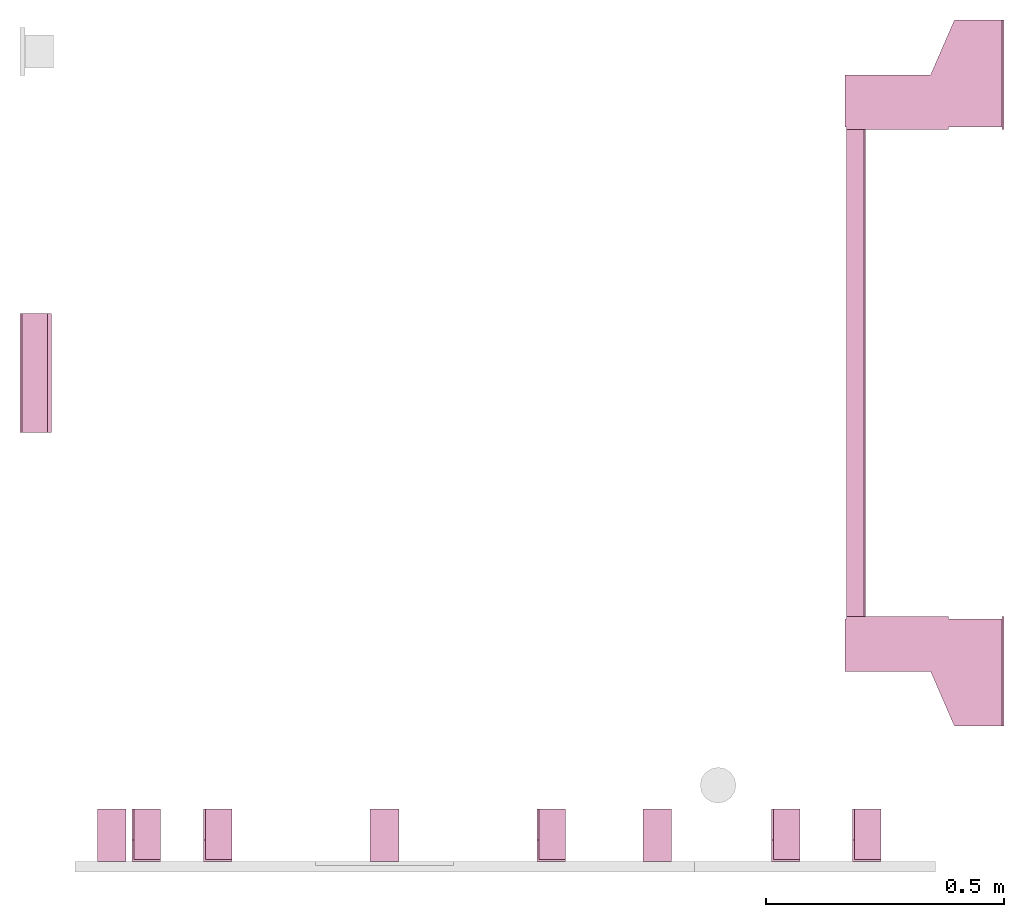
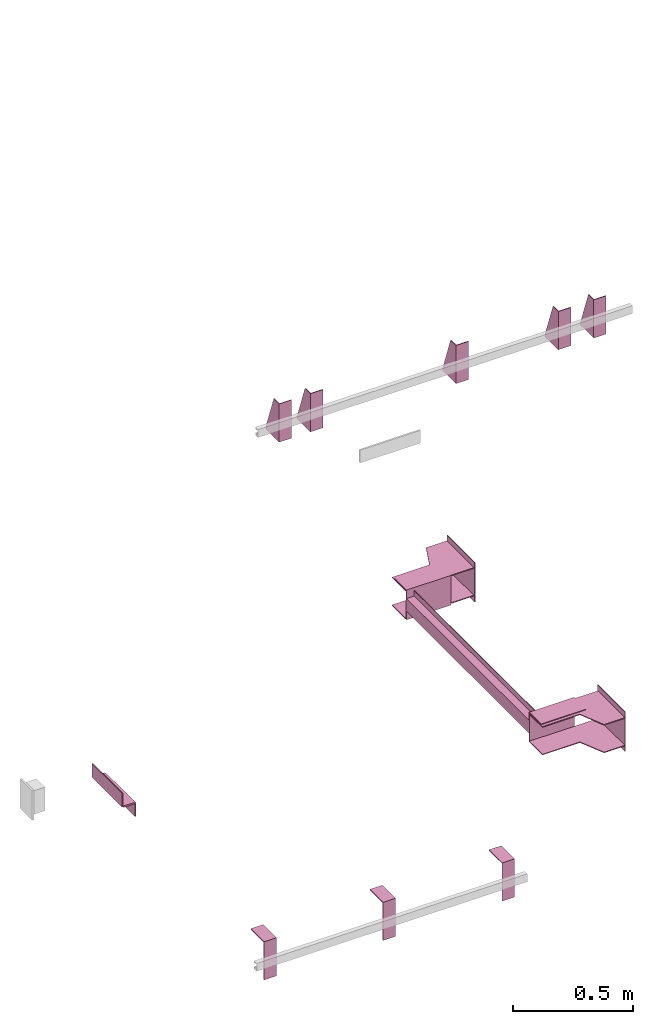
# One storey, part 4 of 4: 10 transport elements.
"""IFC4 building model written with IfcOpenShell, lengths in millimetres."""

from ifc_helpers import new_model, entity, si_unit, converted_unit, frame, origin_with_axes, place, context, subcontext, project, spatial, faceted_brep, element, save


model = new_model("IFC4")

# Units and contexts
context_of_model = context(None, 3, precision=0.01, world=origin_with_axes())
sub_context_1 = subcontext(context_of_model, None, None, "MODEL_VIEW")
sub_context_2 = subcontext(context_of_model, None, None, "MODEL_VIEW")
sub_context_3 = subcontext(context_of_model, None, None, "MODEL_VIEW")
sub_context_4 = subcontext(context_of_model, None, None, "MODEL_VIEW")
sub_context_5 = subcontext(context_of_model, None, None, "MODEL_VIEW")
sub_context_6 = subcontext(context_of_model, None, None, "MODEL_VIEW")
sub_context_7 = subcontext(context_of_model, None, None, "MODEL_VIEW")
sub_context_8 = subcontext(context_of_model, None, None, "MODEL_VIEW")
sub_context_9 = subcontext(context_of_model, None, None, "MODEL_VIEW")
sub_context_10 = subcontext(context_of_model, None, None, "MODEL_VIEW")
ifc_project = project(units=[converted_unit("PLANEANGLEUNIT", "degree", entity("IfcPlaneAngleMeasure", 0.017453292519943), si_unit("PLANEANGLEUNIT", "RADIAN"), dimensions=[0, 0, 0, 0, 0, 0, 0]), si_unit("LENGTHUNIT", "METRE", prefix="MILLI"), si_unit("MASSUNIT", "GRAM", prefix="KILO"), converted_unit("TIMEUNIT", "year", entity("IfcTimeMeasure", 31557600.0), si_unit("TIMEUNIT", "SECOND"), dimensions=[0, 0, 1, 0, 0, 0, 0]), si_unit("THERMODYNAMICTEMPERATUREUNIT", "DEGREE_CELSIUS"), si_unit("AREAUNIT", "SQUARE_METRE"), si_unit("FORCEUNIT", "NEWTON"), si_unit("VOLUMEUNIT", "CUBIC_METRE"), si_unit("PRESSUREUNIT", "PASCAL"), si_unit("SOLIDANGLEUNIT", "STERADIAN")], contexts=[context_of_model])

# Site, building, storey
site = spatial("IfcSite", under=ifc_project)
building = spatial("IfcBuilding", under=site, Name="Document")
placement = place(None, origin_with_axes())
storey_placement = place(placement, frame((0.0, 0.0, -20400.0), z_axis=(0.0, 0.0, 1.0), x_axis=(1.0, 0.0, 0.0)))
storey = spatial("IfcBuildingStorey", under=building, at=storey_placement, Name="P8", Elevation=-20400.0)

# Transport elements
transport_element_1_placement = place(storey_placement, frame((2065.0, 1025.0, 200.0), z_axis=(0.0, 0.0, 1.0), x_axis=(0.0, 1.0, 0.0)))
element("IfcTransportElement", 1, at=transport_element_1_placement, inside=storey, PredefinedType="ELEVATOR", context=sub_context_1, shape_type="Brep", body=[
    faceted_brep([(-611.0, 331.0, -72.5), (-514.0, 331.0, -72.5), (-514.0, 331.0, 72.5), (-611.0, 331.0, 72.5), (-611.0, 331.0, 75.5), (-511.0, 331.0, 75.5), (-511.0, 331.0, -75.5), (-611.0, 331.0, -75.5), (-511.0, 116.0, -75.5), (-511.0, 116.0, 75.5), (-611.0, 116.0, 75.5), (-611.0, 116.0, 72.5), (-514.0, 116.0, 72.5), (-514.0, 116.0, -72.5), (-611.0, 116.0, -72.5), (-611.0, 116.0, -75.5)], [[[0, 1, 2, 3, 4, 5, 6, 7]], [[8, 9, 10, 11, 12, 13, 14, 15]], [[15, 14, 0, 7]], [[13, 12, 2, 1]], [[5, 9, 8, 6]], [[11, 10, 4, 3]], [[6, 8, 15, 7]], [[14, 13, 1, 0]], [[2, 12, 11, 3]], [[10, 9, 5, 4]]]),
    faceted_brep([(-511.0, 291.0, 59.5), (-511.0, 294.0, 59.5), (-511.0, 294.0, 32.5), (-511.0, 291.0, 32.5), (511.0, 291.0, 59.5), (511.0, 291.0, 32.5), (511.0, 294.0, 32.5), (511.0, 294.0, 59.5)], [[[0, 1, 2, 3]], [[4, 5, 6, 7]], [[0, 3, 5, 4]], [[3, 2, 6, 5]], [[2, 1, 7, 6]], [[1, 0, 4, 7]]]),
    faceted_brep([(511.0, 331.0, 75.5), (611.0, 331.0, 75.5), (611.0, 331.0, 72.5), (514.0, 331.0, 72.5), (514.0, 331.0, -72.5), (611.0, 331.0, -72.5), (611.0, 331.0, -75.5), (511.0, 331.0, -75.5), (511.0, 116.0, -75.5), (611.0, 116.0, -75.5), (611.0, 116.0, -72.5), (514.0, 116.0, -72.5), (514.0, 116.0, 72.5), (611.0, 116.0, 72.5), (611.0, 116.0, 75.5), (511.0, 116.0, 75.5)], [[[0, 1, 2, 3, 4, 5, 6, 7]], [[8, 9, 10, 11, 12, 13, 14, 15]], [[8, 15, 0, 7]], [[3, 12, 11, 4]], [[5, 10, 9, 6]], [[1, 14, 13, 2]], [[6, 9, 8, 7]], [[11, 10, 5, 4]], [[15, 14, 1, 0]], [[2, 13, 12, 3]]]),
    faceted_brep([(-511.0, 291.0, -32.5), (-511.0, 294.0, -32.5), (-511.0, 294.0, -59.5), (-511.0, 291.0, -59.5), (511.0, 291.0, -32.5), (511.0, 291.0, -59.5), (511.0, 294.0, -59.5), (511.0, 294.0, -32.5)], [[[0, 1, 2, 3]], [[4, 5, 6, 7]], [[0, 3, 5, 4]], [[3, 2, 6, 5]], [[2, 1, 7, 6]], [[1, 0, 4, 7]]]),
    faceted_brep([(-511.0, 331.0, 32.5), (511.0, 331.0, 32.5), (511.0, 331.0, -32.5), (-511.0, 331.0, -32.5), (511.0, 328.0, -29.5), (511.0, 328.0, 29.5), (-511.0, 328.0, 29.5), (-511.0, 328.0, -29.5), (511.0, 291.0, -32.5), (511.0, 291.0, -29.5), (-511.0, 291.0, -29.5), (-511.0, 291.0, -32.5), (511.0, 291.0, 29.5), (511.0, 291.0, 32.5), (-511.0, 291.0, 32.5), (-511.0, 291.0, 29.5)], [[[0, 1, 2, 3]], [[4, 5, 6, 7]], [[8, 9, 10, 11]], [[12, 13, 14, 15]], [[11, 10, 7, 6, 15, 14, 0, 3]], [[2, 1, 13, 12, 5, 4, 9, 8]], [[2, 8, 11, 3]], [[10, 9, 4, 7]], [[14, 13, 1, 0]], [[5, 12, 15, 6]]]),
    faceted_brep([(-626.0, 334.0, 72.5), (-516.0, 334.0, 72.5), (-516.0, 334.0, 68.5), (-626.0, 334.0, 68.5), (-516.0, 4.0, 68.5), (-516.0, 4.0, 72.5), (-741.0, 4.0, 72.5), (-741.0, 4.0, 68.5), (-741.0, 104.0, 72.5), (-626.0, 154.0, 72.5), (-626.0, 154.0, 68.5), (-741.0, 104.0, 68.5)], [[[0, 1, 2, 3]], [[4, 5, 6, 7]], [[8, 9, 10, 11]], [[10, 9, 0, 3]], [[1, 5, 4, 2]], [[7, 6, 8, 11]], [[2, 4, 7, 11, 10, 3]], [[9, 8, 6, 5, 1, 0]]]),
    faceted_brep([(516.0, 334.0, -68.5), (626.0, 334.0, -68.5), (626.0, 334.0, -72.5), (516.0, 334.0, -72.5), (741.0, 4.0, -72.5), (741.0, 4.0, -68.5), (516.0, 4.0, -68.5), (516.0, 4.0, -72.5), (626.0, 154.0, -68.5), (741.0, 104.0, -68.5), (741.0, 104.0, -72.5), (626.0, 154.0, -72.5)], [[[0, 1, 2, 3]], [[4, 5, 6, 7]], [[8, 9, 10, 11]], [[7, 6, 0, 3]], [[1, 8, 11, 2]], [[9, 5, 4, 10]], [[2, 11, 10, 4, 7, 3]], [[6, 5, 9, 8, 1, 0]]]),
    faceted_brep([(741.0, 0.0, -100.0), (741.0, 0.0, 100.0), (511.0, 0.0, 100.0), (511.0, 0.0, -100.0), (741.0, 4.0, -100.0), (511.0, 4.0, -100.0), (511.0, 4.0, 100.0), (741.0, 4.0, 100.0)], [[[0, 1, 2, 3]], [[4, 5, 6, 7]], [[0, 3, 5, 4]], [[3, 2, 6, 5]], [[2, 1, 7, 6]], [[1, 0, 4, 7]]]),
    faceted_brep([(-626.0, 334.0, -68.5), (-516.0, 334.0, -68.5), (-516.0, 334.0, -72.5), (-626.0, 334.0, -72.5), (-516.0, 4.0, -72.5), (-516.0, 4.0, -68.5), (-741.0, 4.0, -68.5), (-741.0, 4.0, -72.5), (-741.0, 104.0, -68.5), (-626.0, 154.0, -68.5), (-626.0, 154.0, -72.5), (-741.0, 104.0, -72.5)], [[[0, 1, 2, 3]], [[4, 5, 6, 7]], [[8, 9, 10, 11]], [[10, 9, 0, 3]], [[1, 5, 4, 2]], [[7, 6, 8, 11]], [[2, 4, 7, 11, 10, 3]], [[9, 8, 6, 5, 1, 0]]]),
    faceted_brep([(516.0, 334.0, 72.5), (626.0, 334.0, 72.5), (626.0, 334.0, 68.5), (516.0, 334.0, 68.5), (741.0, 4.0, 68.5), (741.0, 4.0, 72.5), (516.0, 4.0, 72.5), (516.0, 4.0, 68.5), (626.0, 154.0, 72.5), (741.0, 104.0, 72.5), (741.0, 104.0, 68.5), (626.0, 154.0, 68.5)], [[[0, 1, 2, 3]], [[4, 5, 6, 7]], [[8, 9, 10, 11]], [[7, 6, 0, 3]], [[1, 8, 11, 2]], [[9, 5, 4, 10]], [[2, 11, 10, 4, 7, 3]], [[6, 5, 9, 8, 1, 0]]]),
    faceted_brep([(-511.0, 0.0, -100.0), (-511.0, 0.0, 100.0), (-741.0, 0.0, 100.0), (-741.0, 0.0, -100.0), (-511.0, 4.0, -100.0), (-741.0, 4.0, -100.0), (-741.0, 4.0, 100.0), (-511.0, 4.0, 100.0)], [[[0, 1, 2, 3]], [[4, 5, 6, 7]], [[0, 3, 5, 4]], [[3, 2, 6, 5]], [[2, 1, 7, 6]], [[1, 0, 4, 7]]]),
])
transport_element_2_placement = place(storey_placement, frame((265.0, 0.0, 2580.0), z_axis=(0.0, 0.0, 1.0), x_axis=(1.0, 0.0, 0.0)))
element("IfcTransportElement", 2, at=transport_element_2_placement, inside=storey, PredefinedType="ELEVATOR", context=sub_context_2, shape_type="Brep", body=[
    faceted_brep([(-30.0, 0.0, -97.0), (-30.0, 0.0, 97.0), (-30.0, 4.0, 97.0), (-30.0, 4.0, -93.0), (-30.0, 110.0, -93.0), (-30.0, 110.0, -97.0), (30.0, 110.0, -97.0), (30.0, 110.0, -93.0), (30.0, 4.0, -93.0), (30.0, 4.0, 97.0), (30.0, 0.0, 97.0), (30.0, 0.0, -97.0)], [[[0, 1, 2, 3, 4, 5]], [[6, 7, 8, 9, 10, 11]], [[11, 10, 1, 0]], [[2, 9, 8, 3]], [[4, 7, 6, 5]], [[5, 6, 11, 0]], [[8, 7, 4, 3]], [[10, 9, 2, 1]]]),
    faceted_brep([(-30.0, 4.0, -93.0), (-30.0, 4.0, 97.0), (-30.0, 45.0, 97.0), (-30.0, 110.0, -82.0), (-30.0, 110.0, -93.0), (-26.0, 4.0, -93.0), (-26.0, 110.0, -93.0), (-26.0, 110.0, -82.0), (-26.0, 45.0, 97.0), (-26.0, 4.0, 97.0)], [[[0, 1, 2, 3, 4]], [[5, 6, 7, 8, 9]], [[5, 0, 4, 6]], [[6, 4, 3, 7]], [[7, 3, 2, 8]], [[8, 2, 1, 9]], [[9, 1, 0, 5]]]),
])
transport_element_3_placement = place(storey_placement, frame((415.0, 0.0, 2580.0), z_axis=(0.0, 0.0, 1.0), x_axis=(1.0, 0.0, 0.0)))
element("IfcTransportElement", 3, at=transport_element_3_placement, inside=storey, PredefinedType="ELEVATOR", context=sub_context_3, shape_type="Brep", body=[
    faceted_brep([(-30.0, 0.0, -97.0), (-30.0, 0.0, 97.0), (-30.0, 4.0, 97.0), (-30.0, 4.0, -93.0), (-30.0, 110.0, -93.0), (-30.0, 110.0, -97.0), (30.0, 110.0, -97.0), (30.0, 110.0, -93.0), (30.0, 4.0, -93.0), (30.0, 4.0, 97.0), (30.0, 0.0, 97.0), (30.0, 0.0, -97.0)], [[[0, 1, 2, 3, 4, 5]], [[6, 7, 8, 9, 10, 11]], [[11, 10, 1, 0]], [[2, 9, 8, 3]], [[4, 7, 6, 5]], [[5, 6, 11, 0]], [[8, 7, 4, 3]], [[10, 9, 2, 1]]]),
    faceted_brep([(-30.0, 4.0, -93.0), (-30.0, 4.0, 97.0), (-30.0, 45.0, 97.0), (-30.0, 110.0, -82.0), (-30.0, 110.0, -93.0), (-26.0, 4.0, -93.0), (-26.0, 110.0, -93.0), (-26.0, 110.0, -82.0), (-26.0, 45.0, 97.0), (-26.0, 4.0, 97.0)], [[[0, 1, 2, 3, 4]], [[5, 6, 7, 8, 9]], [[5, 0, 4, 6]], [[6, 4, 3, 7]], [[7, 3, 2, 8]], [[8, 2, 1, 9]], [[9, 1, 0, 5]]]),
])
transport_element_4_placement = place(storey_placement, frame((1115.0, 0.0, 2580.0), z_axis=(0.0, 0.0, 1.0), x_axis=(1.0, 0.0, 0.0)))
element("IfcTransportElement", 4, at=transport_element_4_placement, inside=storey, PredefinedType="ELEVATOR", context=sub_context_4, shape_type="Brep", body=[
    faceted_brep([(-30.0, 4.0, -93.0), (-30.0, 4.0, 97.0), (-30.0, 45.0, 97.0), (-30.0, 110.0, -82.0), (-30.0, 110.0, -93.0), (-26.0, 4.0, -93.0), (-26.0, 110.0, -93.0), (-26.0, 110.0, -82.0), (-26.0, 45.0, 97.0), (-26.0, 4.0, 97.0)], [[[0, 1, 2, 3, 4]], [[5, 6, 7, 8, 9]], [[5, 0, 4, 6]], [[6, 4, 3, 7]], [[7, 3, 2, 8]], [[8, 2, 1, 9]], [[9, 1, 0, 5]]]),
    faceted_brep([(-30.0, 0.0, -97.0), (-30.0, 0.0, 97.0), (-30.0, 4.0, 97.0), (-30.0, 4.0, -93.0), (-30.0, 110.0, -93.0), (-30.0, 110.0, -97.0), (30.0, 110.0, -97.0), (30.0, 110.0, -93.0), (30.0, 4.0, -93.0), (30.0, 4.0, 97.0), (30.0, 0.0, 97.0), (30.0, 0.0, -97.0)], [[[0, 1, 2, 3, 4, 5]], [[6, 7, 8, 9, 10, 11]], [[11, 10, 1, 0]], [[2, 9, 8, 3]], [[4, 7, 6, 5]], [[5, 6, 11, 0]], [[8, 7, 4, 3]], [[10, 9, 2, 1]]]),
])
transport_element_5_placement = place(storey_placement, frame((1607.0, 0.0, 2580.0), z_axis=(0.0, 0.0, 1.0), x_axis=(1.0, 0.0, 0.0)))
element("IfcTransportElement", 5, at=transport_element_5_placement, inside=storey, PredefinedType="ELEVATOR", context=sub_context_5, shape_type="Brep", body=[
    faceted_brep([(-30.0, 0.0, -97.0), (-30.0, 0.0, 97.0), (-30.0, 4.0, 97.0), (-30.0, 4.0, -93.0), (-30.0, 110.0, -93.0), (-30.0, 110.0, -97.0), (30.0, 110.0, -97.0), (30.0, 110.0, -93.0), (30.0, 4.0, -93.0), (30.0, 4.0, 97.0), (30.0, 0.0, 97.0), (30.0, 0.0, -97.0)], [[[0, 1, 2, 3, 4, 5]], [[6, 7, 8, 9, 10, 11]], [[11, 10, 1, 0]], [[2, 9, 8, 3]], [[4, 7, 6, 5]], [[5, 6, 11, 0]], [[8, 7, 4, 3]], [[10, 9, 2, 1]]]),
    faceted_brep([(-30.0, 4.0, -93.0), (-30.0, 4.0, 97.0), (-30.0, 45.0, 97.0), (-30.0, 110.0, -82.0), (-30.0, 110.0, -93.0), (-26.0, 4.0, -93.0), (-26.0, 110.0, -93.0), (-26.0, 110.0, -82.0), (-26.0, 45.0, 97.0), (-26.0, 4.0, 97.0)], [[[0, 1, 2, 3, 4]], [[5, 6, 7, 8, 9]], [[5, 0, 4, 6]], [[6, 4, 3, 7]], [[7, 3, 2, 8]], [[8, 2, 1, 9]], [[9, 1, 0, 5]]]),
])
transport_element_6_placement = place(storey_placement, frame((1777.0, 0.0, 2580.0), z_axis=(0.0, 0.0, 1.0), x_axis=(1.0, 0.0, 0.0)))
element("IfcTransportElement", 6, at=transport_element_6_placement, inside=storey, PredefinedType="ELEVATOR", context=sub_context_6, shape_type="Brep", body=[
    faceted_brep([(-30.0, 0.0, -97.0), (-30.0, 0.0, 97.0), (-30.0, 4.0, 97.0), (-30.0, 4.0, -93.0), (-30.0, 110.0, -93.0), (-30.0, 110.0, -97.0), (30.0, 110.0, -97.0), (30.0, 110.0, -93.0), (30.0, 4.0, -93.0), (30.0, 4.0, 97.0), (30.0, 0.0, 97.0), (30.0, 0.0, -97.0)], [[[0, 1, 2, 3, 4, 5]], [[6, 7, 8, 9, 10, 11]], [[11, 10, 1, 0]], [[2, 9, 8, 3]], [[4, 7, 6, 5]], [[5, 6, 11, 0]], [[8, 7, 4, 3]], [[10, 9, 2, 1]]]),
    faceted_brep([(-30.0, 4.0, -93.0), (-30.0, 4.0, 97.0), (-30.0, 45.0, 97.0), (-30.0, 110.0, -82.0), (-30.0, 110.0, -93.0), (-26.0, 4.0, -93.0), (-26.0, 110.0, -93.0), (-26.0, 110.0, -82.0), (-26.0, 45.0, 97.0), (-26.0, 4.0, 97.0)], [[[0, 1, 2, 3, 4]], [[5, 6, 7, 8, 9]], [[5, 0, 4, 6]], [[6, 4, 3, 7]], [[7, 3, 2, 8]], [[8, 2, 1, 9]], [[9, 1, 0, 5]]]),
])
transport_element_7_placement = place(storey_placement, frame((1337.5, 0.0, -30.0), z_axis=(0.0, 0.0, -1.0), x_axis=(-1.0, 0.0, 0.0)))
element("IfcTransportElement", 7, at=transport_element_7_placement, inside=storey, PredefinedType="ELEVATOR", context=sub_context_7, shape_type="Brep", body=[
    faceted_brep([(30.0, 0.0, 0.0), (30.0, 110.0, 0.0), (30.0, 110.0, 4.0), (30.0, 4.0, 4.0), (30.0, 4.0, 194.0), (30.0, 0.0, 194.0), (-30.0, 4.0, 194.0), (-30.0, 4.0, 4.0), (-30.0, 110.0, 4.0), (-30.0, 110.0, 0.0), (-30.0, 0.0, 0.0), (-30.0, 0.0, 194.0)], [[[0, 1, 2, 3, 4, 5]], [[6, 7, 8, 9, 10, 11]], [[11, 10, 0, 5]], [[3, 7, 6, 4]], [[1, 9, 8, 2]], [[4, 6, 11, 5]], [[10, 9, 1, 0]], [[2, 8, 7, 3]]]),
    faceted_brep([(-30.0, 4.0, 4.0), (-30.0, 4.0, 194.0), (-30.0, 45.0, 194.0), (-30.0, 110.0, 15.0), (-30.0, 110.0, 4.0), (-26.0, 4.0, 4.0), (-26.0, 110.0, 4.0), (-26.0, 110.0, 15.0), (-26.0, 45.0, 194.0), (-26.0, 4.0, 194.0)], [[[0, 1, 2, 3, 4]], [[5, 6, 7, 8, 9]], [[5, 0, 4, 6]], [[6, 4, 3, 7]], [[7, 3, 2, 8]], [[8, 2, 1, 9]], [[9, 1, 0, 5]]]),
])
transport_element_8_placement = place(storey_placement, frame((765.0, 0.0, -30.0), z_axis=(0.0, 0.0, -1.0), x_axis=(-1.0, 0.0, 0.0)))
element("IfcTransportElement", 8, at=transport_element_8_placement, inside=storey, PredefinedType="ELEVATOR", context=sub_context_8, shape_type="Brep", body=[
    faceted_brep([(30.0, 0.0, 0.0), (30.0, 110.0, 0.0), (30.0, 110.0, 4.0), (30.0, 4.0, 4.0), (30.0, 4.0, 194.0), (30.0, 0.0, 194.0), (-30.0, 4.0, 194.0), (-30.0, 4.0, 4.0), (-30.0, 110.0, 4.0), (-30.0, 110.0, 0.0), (-30.0, 0.0, 0.0), (-30.0, 0.0, 194.0)], [[[0, 1, 2, 3, 4, 5]], [[6, 7, 8, 9, 10, 11]], [[11, 10, 0, 5]], [[3, 7, 6, 4]], [[1, 9, 8, 2]], [[4, 6, 11, 5]], [[10, 9, 1, 0]], [[2, 8, 7, 3]]]),
    faceted_brep([(-30.0, 4.0, 4.0), (-30.0, 4.0, 194.0), (-30.0, 45.0, 194.0), (-30.0, 110.0, 15.0), (-30.0, 110.0, 4.0), (-26.0, 4.0, 4.0), (-26.0, 110.0, 4.0), (-26.0, 110.0, 15.0), (-26.0, 45.0, 194.0), (-26.0, 4.0, 194.0)], [[[0, 1, 2, 3, 4]], [[5, 6, 7, 8, 9]], [[5, 0, 4, 6]], [[6, 4, 3, 7]], [[7, 3, 2, 8]], [[8, 2, 1, 9]], [[9, 1, 0, 5]]]),
])
transport_element_9_placement = place(storey_placement, frame((192.5, 0.0, -30.0), z_axis=(0.0, 0.0, -1.0), x_axis=(-1.0, 0.0, 0.0)))
element("IfcTransportElement", 9, at=transport_element_9_placement, inside=storey, PredefinedType="ELEVATOR", context=sub_context_9, shape_type="Brep", body=[
    faceted_brep([(-30.0, 4.0, 4.0), (-30.0, 4.0, 194.0), (-30.0, 45.0, 194.0), (-30.0, 110.0, 15.0), (-30.0, 110.0, 4.0), (-26.0, 4.0, 4.0), (-26.0, 110.0, 4.0), (-26.0, 110.0, 15.0), (-26.0, 45.0, 194.0), (-26.0, 4.0, 194.0)], [[[0, 1, 2, 3, 4]], [[5, 6, 7, 8, 9]], [[5, 0, 4, 6]], [[6, 4, 3, 7]], [[7, 3, 2, 8]], [[8, 2, 1, 9]], [[9, 1, 0, 5]]]),
    faceted_brep([(30.0, 0.0, 0.0), (30.0, 110.0, 0.0), (30.0, 110.0, 4.0), (30.0, 4.0, 4.0), (30.0, 4.0, 194.0), (30.0, 0.0, 194.0), (-30.0, 4.0, 194.0), (-30.0, 4.0, 4.0), (-30.0, 110.0, 4.0), (-30.0, 110.0, 0.0), (-30.0, 0.0, 0.0), (-30.0, 0.0, 194.0)], [[[0, 1, 2, 3, 4, 5]], [[6, 7, 8, 9, 10, 11]], [[11, 10, 0, 5]], [[3, 7, 6, 4]], [[1, 9, 8, 2]], [[4, 6, 11, 5]], [[10, 9, 1, 0]], [[2, 8, 7, 3]]]),
])
transport_element_10_placement = place(storey_placement, frame((0.0, 1025.0, 200.0), z_axis=(0.0, 0.0, 1.0), x_axis=(0.0, -1.0, 0.0)))
element("IfcTransportElement", 10, at=transport_element_10_placement, inside=storey, PredefinedType="ELEVATOR", context=sub_context_10, shape_type="Brep", body=[
    faceted_brep([(125.0, 0.0, 35.0), (-125.0, 0.0, 35.0), (-125.0, 0.0, -35.0), (125.0, 0.0, -35.0), (-125.0, 4.0, -31.0), (-125.0, 4.0, 35.0), (125.0, 4.0, 35.0), (125.0, 4.0, -31.0), (-125.0, 58.0, -35.0), (-125.0, 58.0, -31.0), (125.0, 58.0, -31.0), (125.0, 58.0, -35.0)], [[[0, 1, 2, 3]], [[4, 5, 6, 7]], [[8, 9, 10, 11]], [[11, 10, 7, 6, 0, 3]], [[2, 1, 5, 4, 9, 8]], [[2, 8, 11, 3]], [[10, 9, 4, 7]], [[6, 5, 1, 0]]]),
    faceted_brep([(125.0, 8.0, -35.0), (-125.0, 8.0, -35.0), (-125.0, 8.0, -39.0), (125.0, 8.0, -39.0), (125.0, 62.0, -39.0), (-125.0, 62.0, -39.0), (-125.0, 62.0, -105.0), (125.0, 62.0, -105.0), (-125.0, 66.0, -105.0), (-125.0, 66.0, -35.0), (125.0, 66.0, -35.0), (125.0, 66.0, -105.0)], [[[0, 1, 2, 3]], [[4, 5, 6, 7]], [[8, 9, 10, 11]], [[4, 7, 11, 10, 0, 3]], [[1, 9, 8, 6, 5, 2]], [[2, 5, 4, 3]], [[10, 9, 1, 0]], [[6, 8, 11, 7]]]),
])

save(model, "model.ifc")
